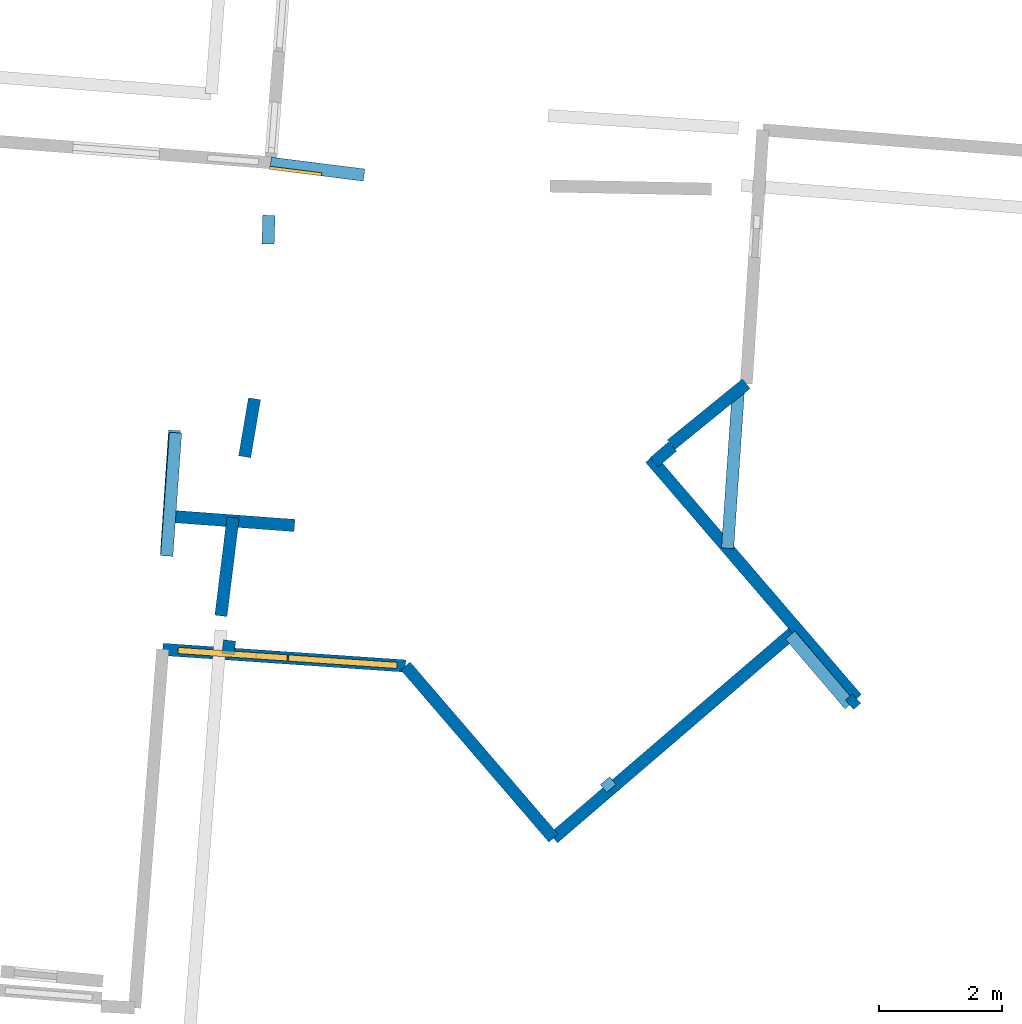
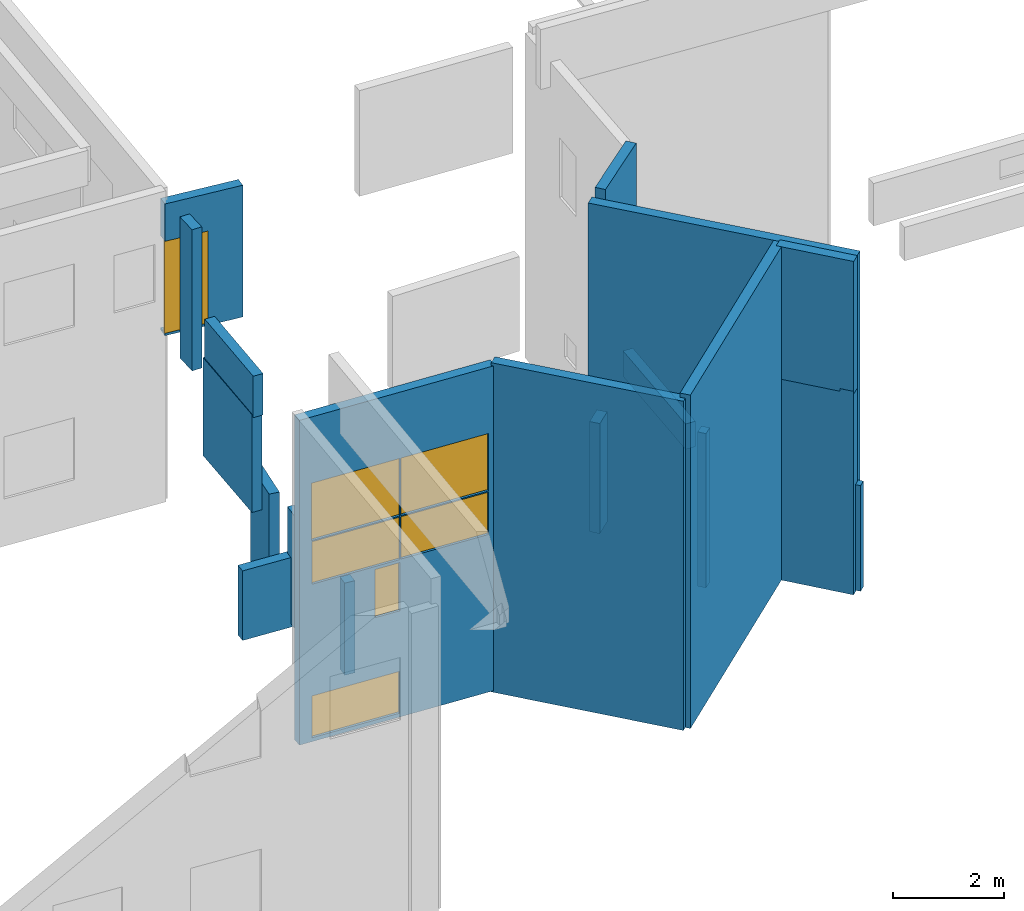
# One storey, part 20 of 27: 19 walls, 6 windows, 1 door, 7 openings.
"""IFC2X3 building model written with IfcOpenShell, lengths in metres."""

from ifc_helpers import new_model, entity, si_unit, converted_unit, derived_unit, direction, frame, frame_2d, origin, origin_2d_with_axis, place, context, subcontext, project, spatial, polyline, rectangle, outline, extrude, source, transform, mapped, material, layer, layer_set, layer_usage, type_object, type_shapes, element, fill, save


model = new_model("IFC2X3")

# Units and contexts
model_context = context("Model", 3, precision=1e-05, world=origin(), true_north=direction((0.0, 1.0)))
body_context = subcontext(model_context, "Body", "Model", "MODEL_VIEW")
ifc_project = project(units=[si_unit("LENGTHUNIT", "METRE"), si_unit("AREAUNIT", "SQUARE_METRE"), si_unit("VOLUMEUNIT", "CUBIC_METRE"), converted_unit("PLANEANGLEUNIT", "DEGREE", entity("IfcRatioMeasure", 0.0174532925199433), si_unit("PLANEANGLEUNIT", "RADIAN"), dimensions=[0, 0, 0, 0, 0, 0, 0]), si_unit("MASSUNIT", "GRAM", prefix="KILO"), derived_unit("MASSDENSITYUNIT", [(si_unit("MASSUNIT", "GRAM", prefix="KILO"), 1), (si_unit("LENGTHUNIT", "METRE"), -3)]), derived_unit("MOMENTOFINERTIAUNIT", [(si_unit("LENGTHUNIT", "METRE"), 4)]), si_unit("TIMEUNIT", "SECOND"), si_unit("FREQUENCYUNIT", "HERTZ"), si_unit("THERMODYNAMICTEMPERATUREUNIT", "DEGREE_CELSIUS"), derived_unit("THERMALTRANSMITTANCEUNIT", [(si_unit("MASSUNIT", "GRAM", prefix="KILO"), 1), (si_unit("THERMODYNAMICTEMPERATUREUNIT", "KELVIN"), -1), (si_unit("TIMEUNIT", "SECOND"), -3)]), derived_unit("VOLUMETRICFLOWRATEUNIT", [(si_unit("LENGTHUNIT", "METRE"), 3), (si_unit("TIMEUNIT", "SECOND"), -1)]), si_unit("ELECTRICCURRENTUNIT", "AMPERE"), si_unit("ELECTRICVOLTAGEUNIT", "VOLT"), si_unit("POWERUNIT", "WATT"), si_unit("FORCEUNIT", "NEWTON", prefix="KILO"), si_unit("ILLUMINANCEUNIT", "LUX"), si_unit("LUMINOUSFLUXUNIT", "LUMEN"), si_unit("LUMINOUSINTENSITYUNIT", "CANDELA"), derived_unit("USERDEFINED", [(si_unit("MASSUNIT", "GRAM", prefix="KILO"), -1), (si_unit("LENGTHUNIT", "METRE"), -2), (si_unit("TIMEUNIT", "SECOND"), 3), (si_unit("LUMINOUSFLUXUNIT", "LUMEN"), 1)]), derived_unit("LINEARVELOCITYUNIT", [(si_unit("LENGTHUNIT", "METRE"), 1), (si_unit("TIMEUNIT", "SECOND"), -1)]), si_unit("PRESSUREUNIT", "PASCAL"), derived_unit("USERDEFINED", [(si_unit("LENGTHUNIT", "METRE"), -2), (si_unit("MASSUNIT", "GRAM", prefix="KILO"), 1), (si_unit("TIMEUNIT", "SECOND"), -2)]), derived_unit("LINEARFORCEUNIT", [(si_unit("MASSUNIT", "GRAM", prefix="KILO"), 1), (si_unit("LENGTHUNIT", "METRE"), 1), (si_unit("TIMEUNIT", "SECOND"), -2), (si_unit("LENGTHUNIT", "METRE"), -1)]), derived_unit("PLANARFORCEUNIT", [(si_unit("MASSUNIT", "GRAM", prefix="KILO"), 1), (si_unit("LENGTHUNIT", "METRE"), 1), (si_unit("TIMEUNIT", "SECOND"), -2), (si_unit("LENGTHUNIT", "METRE"), -2)])], contexts=[model_context])

# Site, building, storey
placement_1 = place(None, origin())
site = spatial("IfcSite", under=ifc_project, at=placement_1, CompositionType="ELEMENT")
building = spatial("IfcBuilding", under=site, at=placement_1, CompositionType="ELEMENT")
storey_placement = place(placement_1, frame((0.0, 0.0, -61.043098449707)))
storey = spatial("IfcBuildingStorey", under=building, at=storey_placement, Name="level_-61.043098", CompositionType="ELEMENT", Elevation=-61.043098449707)

# Walls
ifc_material_1 = material(Name="Default wall")
ifc_layer = layer(ifc_material_1, 0.2)
ifc_layer_set = layer_set([ifc_layer], Name="wall_thickness_0.2000")
ifc_layer_usage = layer_usage(ifc_layer_set, "AXIS2", "POSITIVE", -0.1)
wall_type = type_object("IfcWallType", Name="wall_thickness_0.2000", PredefinedType="STANDARD", material=ifc_layer_set)
placement_2 = place(placement_1, frame((0.0, 0.0, -59.9867630004883)))
wall_1_placement = place(placement_2, frame((3.72674454788199, -11.2180792939364, 0.0), z_axis=(0.0, 0.0, 1.0), x_axis=(-0.122635622552164, -0.992451764108082, 0.0)))
element("IfcWallStandardCase", 1, at=wall_1_placement, inside=storey, type_object=wall_type, material=ifc_layer_usage, Name="Wall:43", ObjectType="Wall", context=body_context, shape_type="SweptSolid", body=[
    extrude(outline(polyline([(1.6065191620896, -0.1), (1.6065191620896, 0.1), (0.0, 0.1), (0.0, -0.1), (1.6065191620896, -0.1)])), origin(), (0.0, 0.0, 1.0), 2.48210144042969),
])
placement_3 = place(placement_1, frame((0.0, 0.0, -56.6423950195312)))
wall_2_placement = place(placement_3, frame((13.7307276761627, -14.256990154621, 0.0), z_axis=(0.0, 0.0, 1.0), x_axis=(-0.648596376151792, 0.761132538289333, 0.0)))
element("IfcWallStandardCase", 2, at=wall_2_placement, inside=storey, type_object=wall_type, material=ifc_layer_usage, Name="Wall:146", ObjectType="Wall", context=body_context, shape_type="SweptSolid", body=[
    extrude(outline(polyline([(1.48869451366512, -0.1), (1.48869451366512, 0.1), (0.0, 0.1), (0.0, -0.1), (1.48869451366512, -0.1)])), origin(), (0.0, 0.0, 1.0), 2.9259033203125),
])

# Wall, opening, door
placement_4 = place(placement_1, frame((0.0, 0.0, -57.3973922729492)))
wall_3_placement = place(placement_4, frame((5.85279650664153, -5.66056494307114, 0.0), z_axis=(0.0, 0.0, 1.0), x_axis=(-0.992131659614174, 0.125198921685551, 0.0)))
wall_3 = element("IfcWallStandardCase", 3, at=wall_3_placement, inside=storey, type_object=wall_type, material=ifc_layer_usage, Name="Wall:167", ObjectType="Wall", context=body_context, shape_type="SweptSolid", body=[
    extrude(outline(polyline([(1.52899989557727, -0.1), (1.52899989557727, 0.1), (0.0, 0.1), (0.0, -0.1), (1.52899989557727, -0.1)])), origin(), (0.0, 0.0, 1.0), 2.90872955322266),
])
opening_1_placement = place(wall_3_placement, frame((0.685000048983913, -0.1, 0.0537300109863281)))
opening_1 = element("IfcOpeningElement", 4, at=opening_1_placement, cuts=wall_3, Name="Opening : 850 x 2030 : 11", ObjectType="Opening", context=body_context, shape_type="SweptSolid", body=[
    extrude(rectangle(XDim=0.85, YDim=2.03, at=frame_2d((1.015, 0.425), x_axis=(0.0, 1.0))), frame((0.0, 0.0, 0.0), z_axis=(0.0, 1.0, 0.0), x_axis=(0.0, 0.0, 1.0)), (0.0, 0.0, 1.0), 0.2),
])
ifc_material_2 = material(Name="Door Panel")
door_style = type_object("IfcDoorStyle", Name="Door : 850 x 2030mm", ConstructionType="NOTDEFINED", OperationType="SINGLE_SWING_RIGHT", ParameterTakesPrecedence=False, Sizeable=False, material=ifc_material_2)
shared_shape_1 = source(origin(), body_context, "Body", "SweptSolid", [
    extrude(rectangle(XDim=0.05, YDim=0.85, at=origin_2d_with_axis()), frame((0.425, 0.175, 0.0), z_axis=(0.0, 0.0, 1.0), x_axis=(0.0, 1.0, 0.0)), (0.0, 0.0, 1.0), 2.03),
])
type_shapes(door_style, [shared_shape_1])
door_placement = place(opening_1_placement, origin())
door = element("IfcDoor", 5, at=door_placement, inside=storey, type_object=door_style, Name="Door : 850 x 2030mm : 1", ObjectType="Door : 850 x 2030mm", OverallHeight=2.03, OverallWidth=0.85, context=body_context, shape_type="MappedRepresentation", body=[
    mapped(shared_shape_1, transform((0.0, 0.0, 0.0), scale=1.0)),
])
fill(opening_1, door)

# Walls
wall_4_placement = place(storey_placement, frame((13.8453943914208, -14.1546270377382, 0.0), z_axis=(0.0, 0.0, 1.0), x_axis=(-0.754916049005397, -0.655821438315401, 0.0)))
element("IfcWallStandardCase", 6, at=wall_4_placement, inside=storey, type_object=wall_type, material=ifc_layer_usage, Name="Wall:279", ObjectType="Wall", context=body_context, shape_type="SweptSolid", body=[
    extrude(outline(polyline([(0.154540212290248, -0.1), (0.154540212290248, 0.1), (0.0, 0.1), (0.0, -0.1), (0.154540212290248, -0.1)])), origin(), (0.0, 0.0, 1.0), 2.33486175537109),
])
placement_5 = place(placement_1, frame((0.0, 0.0, -58.7488288879395)))
wall_5_placement = place(placement_5, frame((9.86514925137134, -15.6132291871711, 0.0), z_axis=(0.0, 0.0, 1.0), x_axis=(-0.63309080364225, 0.774077537681859, 0.0)))
element("IfcWallStandardCase", 7, at=wall_5_placement, inside=storey, type_object=wall_type, material=ifc_layer_usage, Name="Wall:407", ObjectType="Wall", context=body_context, shape_type="SweptSolid", body=[
    extrude(outline(polyline([(0.165718194954943, -0.1), (0.165718194954943, 0.1), (0.0, 0.1), (0.0, -0.1), (0.165718194954943, -0.1)])), origin(), (0.0, 0.0, 1.0), 3.40629577636719),
])
placement_6 = place(placement_1, frame((0.0, 0.0, -58.7488288879395)))
wall_6_placement = place(placement_6, frame((11.7499348355875, -11.7163176477874, 0.0), z_axis=(0.0, 0.0, 1.0), x_axis=(0.0680780800533135, 0.997679996299542, 0.0)))
element("IfcWallStandardCase", 8, at=wall_6_placement, inside=storey, type_object=wall_type, material=ifc_layer_usage, Name="Wall:459", ObjectType="Wall", context=body_context, shape_type="SweptSolid", body=[
    extrude(outline(polyline([(2.57255578706574, -0.1), (2.57255578706574, 0.1), (0.0, 0.1), (0.0, -0.1), (2.57255578706574, -0.1)])), origin(), (0.0, 0.0, 1.0), 0.561229705810547),
])
placement_7 = place(placement_1, frame((0.0, 0.0, -61.0783157348633)))
wall_7_placement = place(placement_7, frame((13.7287289435935, -14.2559767905874, 0.0), z_axis=(0.0, 0.0, 1.0), x_axis=(-0.646113240710319, 0.76324156083039, 0.0)))
element("IfcWallStandardCase", 9, at=wall_7_placement, inside=storey, type_object=wall_type, material=ifc_layer_usage, Name="Wall:535", ObjectType="Wall", context=body_context, shape_type="SweptSolid", body=[
    extrude(outline(polyline([(1.48664756935953, -0.1), (1.48664756935953, 0.1), (0.0, 0.1), (0.0, -0.1), (1.48664756935953, -0.1)])), origin(), (0.0, 0.0, 1.0), 4.49478912353516),
])
placement_8 = place(placement_1, frame((0.0, 0.0, -54.7861137390137)))
wall_8_placement = place(placement_8, frame((2.79352791295688, -9.8407572805784, 0.0), z_axis=(0.0, 0.0, 1.0), x_axis=(-0.0711735971793763, -0.997463943741601, 0.0)))
element("IfcWallStandardCase", 10, at=wall_8_placement, inside=storey, type_object=wall_type, material=ifc_layer_usage, Name="Wall:643", ObjectType="Wall", context=body_context, shape_type="SweptSolid", body=[
    extrude(outline(polyline([(2.00499991556981, -0.1), (2.00499991556981, 0.1), (0.0, 0.1), (0.0, -0.1), (2.00499991556981, -0.1)])), origin(), (0.0, 0.0, 1.0), 0.914207458496094),
])
placement_9 = place(placement_1, frame((0.0, 0.0, -61.0783157348633)))
wall_9_placement = place(placement_9, frame((12.877055778141, -13.0278539800355, 0.0), z_axis=(0.0, 0.0, 1.0), x_axis=(-0.758790844108223, -0.651334364898345, 0.0)))
element("IfcWallStandardCase", 11, at=wall_9_placement, inside=storey, type_object=wall_type, material=ifc_layer_usage, Name="Wall:735", ObjectType="Wall", context=body_context, shape_type="SweptSolid", body=[
    extrude(outline(polyline([(5.2068631766687, -0.1), (5.2068631766687, 0.1), (0.0, 0.1), (0.0, -0.1), (5.2068631766687, -0.1)])), origin(), (0.0, 0.0, 1.0), 7.36182403564453),
])
placement_10 = place(placement_1, frame((0.0, 0.0, -61.0783157348633)))
wall_10_placement = place(placement_10, frame((6.52413124766699, -13.6259891294934, 0.0), z_axis=(0.0, 0.0, 1.0), x_axis=(0.65200642014833, -0.758213444938402, 0.0)))
element("IfcWallStandardCase", 12, at=wall_10_placement, inside=storey, type_object=wall_type, material=ifc_layer_usage, Name="Wall:832", ObjectType="Wall", context=body_context, shape_type="SweptSolid", body=[
    extrude(outline(polyline([(3.68401930980512, -0.1), (3.68401930980512, 0.1), (0.0, 0.1), (0.0, -0.1), (3.68401930980512, -0.1)])), origin(), (0.0, 0.0, 1.0), 7.26918411254883),
])
placement_11 = place(placement_1, frame((0.0, 0.0, -56.9013023376465)))
wall_11_placement = place(placement_11, frame((2.77837817486095, -9.80326750753088, 0.0), z_axis=(0.0, 0.0, 1.0), x_axis=(-0.0665947930889778, -0.997780102794918, 0.0)))
element("IfcWallStandardCase", 13, at=wall_11_placement, inside=storey, type_object=wall_type, material=ifc_layer_usage, Name="Wall:977", ObjectType="Wall", context=body_context, shape_type="SweptSolid", body=[
    extrude(outline(polyline([(2.00499925497424, -0.1), (2.00499925497424, 0.1), (0.0, 0.1), (0.0, -0.1), (2.00499925497424, -0.1)])), origin(), (0.0, 0.0, 1.0), 2.16252899169922),
])
placement_12 = place(placement_1, frame((0.0, 0.0, -60.0665283203125)))
wall_12_placement = place(placement_12, frame((3.91493213467944, -10.2315343285394, 0.0), z_axis=(0.0, 0.0, 1.0), x_axis=(0.167306336880324, 0.985904959739876, 0.0)))
element("IfcWallStandardCase", 14, at=wall_12_placement, inside=storey, type_object=wall_type, material=ifc_layer_usage, Name="Wall:1047", ObjectType="Wall", context=body_context, shape_type="SweptSolid", body=[
    extrude(outline(polyline([(0.955000535399188, -0.1), (0.955000535399188, 0.1), (0.0, 0.1), (0.0, -0.1), (0.955000535399188, -0.1)])), origin(), (0.0, 0.0, 1.0), 2.16623687744141),
])
wall_13_placement = place(storey_placement, frame((10.8581595336881, -10.0632953327282, 0.0), z_axis=(0.0, 0.0, 1.0), x_axis=(-0.759124153920514, -0.650945864826303, 0.0)))
element("IfcWallStandardCase", 15, at=wall_13_placement, inside=storey, type_object=wall_type, material=ifc_layer_usage, Name="Wall:1208", ObjectType="Wall", context=body_context, shape_type="SweptSolid", body=[
    extrude(outline(polyline([(0.40106438837095, -0.1), (0.40106438837095, 0.1), (0.0, 0.1), (0.0, -0.1), (0.40106438837095, -0.1)])), origin(), (0.0, 0.0, 1.0), 2.43098831176758),
])

# Wall, openings, windows
wall_14_placement = place(storey_placement, frame((6.52413051795277, -13.6259896343343, 0.0), z_axis=(0.0, 0.0, 1.0), x_axis=(-0.997670095106908, 0.0682230263867892, 0.0)))
wall_14 = element("IfcWallStandardCase", 16, at=wall_14_placement, inside=storey, type_object=wall_type, material=ifc_layer_usage, Name="Wall:1341", ObjectType="Wall", context=body_context, shape_type="SweptSolid", body=[
    extrude(outline(polyline([(3.94824900385597, -0.1), (3.94824900385597, 0.1), (0.0, 0.1), (0.0, -0.1), (3.94824900385597, -0.1)])), origin(), (0.0, 0.0, 1.0), 7.17119216918945),
])
opening_2_placement = place(wall_14_placement, frame((0.139769048185019, -0.1, 4.43975067138672)))
opening_2 = element("IfcOpeningElement", 17, at=opening_2_placement, cuts=wall_14, Name="Opening : 1765 x 1270 : 209", ObjectType="Opening", context=body_context, shape_type="SweptSolid", body=[
    extrude(rectangle(XDim=1.765, YDim=1.27, at=frame_2d((0.635, 0.8825), x_axis=(0.0, 1.0))), frame((0.0, 0.0, 0.0), z_axis=(0.0, 1.0, 0.0), x_axis=(0.0, 0.0, 1.0)), (0.0, 0.0, 1.0), 0.2),
])
opening_3_placement = place(wall_14_placement, frame((1.91976896516112, -0.1, 4.43975067138672)))
opening_3 = element("IfcOpeningElement", 18, at=opening_3_placement, cuts=wall_14, Name="Opening : 1780 x 1270 : 210", ObjectType="Opening", context=body_context, shape_type="SweptSolid", body=[
    extrude(rectangle(XDim=1.78, YDim=1.27, at=frame_2d((0.635, 0.89), x_axis=(0.0, 1.0))), frame((0.0, 0.0, 0.0), z_axis=(0.0, 1.0, 0.0), x_axis=(0.0, 0.0, 1.0)), (0.0, 0.0, 1.0), 0.2),
])
opening_4_placement = place(wall_14_placement, frame((0.139769048185019, -0.1, 3.4797477722168)))
opening_4 = element("IfcOpeningElement", 19, at=opening_4_placement, cuts=wall_14, Name="Opening : 1760 x 935 : 211", ObjectType="Opening", context=body_context, shape_type="SweptSolid", body=[
    extrude(rectangle(XDim=1.76, YDim=0.935, at=frame_2d((0.4675, 0.88), x_axis=(0.0, 1.0))), frame((0.0, 0.0, 0.0), z_axis=(0.0, 1.0, 0.0), x_axis=(0.0, 0.0, 1.0)), (0.0, 0.0, 1.0), 0.2),
])
opening_5_placement = place(wall_14_placement, frame((1.91976896516112, -0.1, 3.47474670410156)))
opening_5 = element("IfcOpeningElement", 20, at=opening_5_placement, cuts=wall_14, Name="Opening : 1775 x 940 : 212", ObjectType="Opening", context=body_context, shape_type="SweptSolid", body=[
    extrude(rectangle(XDim=1.775, YDim=0.94, at=frame_2d((0.47, 0.8875), x_axis=(0.0, 1.0))), frame((0.0, 0.0, 0.0), z_axis=(0.0, 1.0, 0.0), x_axis=(0.0, 0.0, 1.0)), (0.0, 0.0, 1.0), 0.2),
])
opening_6_placement = place(wall_14_placement, frame((1.92476876398627, -0.1, 2.34474945068359)))
opening_6 = element("IfcOpeningElement", 21, at=opening_6_placement, cuts=wall_14, Name="Opening : 505 x 1065 : 213", ObjectType="Opening", context=body_context, shape_type="SweptSolid", body=[
    extrude(rectangle(XDim=0.505, YDim=1.065, at=frame_2d((0.5325, 0.2525), x_axis=(0.0, 1.0))), frame((0.0, 0.0, 0.0), z_axis=(0.0, 1.0, 0.0), x_axis=(0.0, 0.0, 1.0)), (0.0, 0.0, 1.0), 0.2),
])
opening_7_placement = place(wall_14_placement, frame((1.92976910360013, -0.1, 0.084747314453125)))
opening_7 = element("IfcOpeningElement", 22, at=opening_7_placement, cuts=wall_14, Name="Opening : 1765 x 925 : 214", ObjectType="Opening", context=body_context, shape_type="SweptSolid", body=[
    extrude(rectangle(XDim=1.765, YDim=0.925, at=frame_2d((0.4625, 0.8825), x_axis=(0.0, 1.0))), frame((0.0, 0.0, 0.0), z_axis=(0.0, 1.0, 0.0), x_axis=(0.0, 0.0, 1.0)), (0.0, 0.0, 1.0), 0.2),
])
ifc_material_3 = material(Name="Window Default")
window_style_1 = type_object("IfcWindowStyle", Name="Window : 1765 x 1270mm", ConstructionType="NOTDEFINED", OperationType="NOTDEFINED", ParameterTakesPrecedence=False, Sizeable=False, material=ifc_material_3)
shared_shape_2 = source(origin(), body_context, "Body", "SweptSolid", [
    extrude(rectangle(XDim=0.1, YDim=1.765, at=origin_2d_with_axis()), frame((0.8825, 0.1, 0.0), z_axis=(0.0, 0.0, 1.0), x_axis=(0.0, 1.0, 0.0)), (0.0, 0.0, 1.0), 1.27),
])
type_shapes(window_style_1, [shared_shape_2])
window_1_placement = place(opening_2_placement, origin())
window_1 = element("IfcWindow", 23, at=window_1_placement, inside=storey, type_object=window_style_1, Name="Window : 1765 x 1270mm : 192", ObjectType="Window : 1765 x 1270mm", OverallHeight=1.27, OverallWidth=1.765, context=body_context, shape_type="MappedRepresentation", body=[
    mapped(shared_shape_2, transform((0.0, 0.0, 0.0), scale=1.0)),
])
fill(opening_2, window_1)
window_style_2 = type_object("IfcWindowStyle", Name="Window : 1780 x 1270mm", ConstructionType="NOTDEFINED", OperationType="NOTDEFINED", ParameterTakesPrecedence=False, Sizeable=False, material=ifc_material_3)
shared_shape_3 = source(origin(), body_context, "Body", "SweptSolid", [
    extrude(rectangle(XDim=0.1, YDim=1.78, at=origin_2d_with_axis()), frame((0.89, 0.1, 0.0), z_axis=(0.0, 0.0, 1.0), x_axis=(0.0, 1.0, 0.0)), (0.0, 0.0, 1.0), 1.27),
])
type_shapes(window_style_2, [shared_shape_3])
window_2_placement = place(opening_3_placement, origin())
window_2 = element("IfcWindow", 24, at=window_2_placement, inside=storey, type_object=window_style_2, Name="Window : 1780 x 1270mm : 193", ObjectType="Window : 1780 x 1270mm", OverallHeight=1.27, OverallWidth=1.78, context=body_context, shape_type="MappedRepresentation", body=[
    mapped(shared_shape_3, transform((0.0, 0.0, 0.0), scale=1.0)),
])
fill(opening_3, window_2)
window_style_3 = type_object("IfcWindowStyle", Name="Window : 1760 x 935mm", ConstructionType="NOTDEFINED", OperationType="NOTDEFINED", ParameterTakesPrecedence=False, Sizeable=False, material=ifc_material_3)
shared_shape_4 = source(origin(), body_context, "Body", "SweptSolid", [
    extrude(rectangle(XDim=0.1, YDim=1.76, at=origin_2d_with_axis()), frame((0.88, 0.1, 0.0), z_axis=(0.0, 0.0, 1.0), x_axis=(0.0, 1.0, 0.0)), (0.0, 0.0, 1.0), 0.935),
])
type_shapes(window_style_3, [shared_shape_4])
window_3_placement = place(opening_4_placement, origin())
window_3 = element("IfcWindow", 25, at=window_3_placement, inside=storey, type_object=window_style_3, Name="Window : 1760 x 935mm : 194", ObjectType="Window : 1760 x 935mm", OverallHeight=0.935, OverallWidth=1.76, context=body_context, shape_type="MappedRepresentation", body=[
    mapped(shared_shape_4, transform((0.0, 0.0, 0.0), scale=1.0)),
])
fill(opening_4, window_3)
window_style_4 = type_object("IfcWindowStyle", Name="Window : 1775 x 940mm", ConstructionType="NOTDEFINED", OperationType="NOTDEFINED", ParameterTakesPrecedence=False, Sizeable=False, material=ifc_material_3)
shared_shape_5 = source(origin(), body_context, "Body", "SweptSolid", [
    extrude(rectangle(XDim=0.1, YDim=1.775, at=origin_2d_with_axis()), frame((0.8875, 0.1, 0.0), z_axis=(0.0, 0.0, 1.0), x_axis=(0.0, 1.0, 0.0)), (0.0, 0.0, 1.0), 0.94),
])
type_shapes(window_style_4, [shared_shape_5])
window_4_placement = place(opening_5_placement, origin())
window_4 = element("IfcWindow", 26, at=window_4_placement, inside=storey, type_object=window_style_4, Name="Window : 1775 x 940mm : 195", ObjectType="Window : 1775 x 940mm", OverallHeight=0.94, OverallWidth=1.775, context=body_context, shape_type="MappedRepresentation", body=[
    mapped(shared_shape_5, transform((0.0, 0.0, 0.0), scale=1.0)),
])
fill(opening_5, window_4)
window_style_5 = type_object("IfcWindowStyle", Name="Window : 505 x 1065mm", ConstructionType="NOTDEFINED", OperationType="NOTDEFINED", ParameterTakesPrecedence=False, Sizeable=False, material=ifc_material_3)
shared_shape_6 = source(origin(), body_context, "Body", "SweptSolid", [
    extrude(rectangle(XDim=0.1, YDim=0.505, at=origin_2d_with_axis()), frame((0.2525, 0.1, 0.0), z_axis=(0.0, 0.0, 1.0), x_axis=(0.0, 1.0, 0.0)), (0.0, 0.0, 1.0), 1.065),
])
type_shapes(window_style_5, [shared_shape_6])
window_5_placement = place(opening_6_placement, origin())
window_5 = element("IfcWindow", 27, at=window_5_placement, inside=storey, type_object=window_style_5, Name="Window : 505 x 1065mm : 196", ObjectType="Window : 505 x 1065mm", OverallHeight=1.065, OverallWidth=0.505, context=body_context, shape_type="MappedRepresentation", body=[
    mapped(shared_shape_6, transform((0.0, 0.0, 0.0), scale=1.0)),
])
fill(opening_6, window_5)
window_style_6 = type_object("IfcWindowStyle", Name="Window : 1765 x 925mm", ConstructionType="NOTDEFINED", OperationType="NOTDEFINED", ParameterTakesPrecedence=False, Sizeable=False, material=ifc_material_3)
shared_shape_7 = source(origin(), body_context, "Body", "SweptSolid", [
    extrude(rectangle(XDim=0.1, YDim=1.765, at=origin_2d_with_axis()), frame((0.8825, 0.1, 0.0), z_axis=(0.0, 0.0, 1.0), x_axis=(0.0, 1.0, 0.0)), (0.0, 0.0, 1.0), 0.925),
])
type_shapes(window_style_6, [shared_shape_7])
window_6_placement = place(opening_7_placement, origin())
window_6 = element("IfcWindow", 28, at=window_6_placement, inside=storey, type_object=window_style_6, Name="Window : 1765 x 925mm : 197", ObjectType="Window : 1765 x 925mm", OverallHeight=0.925, OverallWidth=1.765, context=body_context, shape_type="MappedRepresentation", body=[
    mapped(shared_shape_7, transform((0.0, 0.0, 0.0), scale=1.0)),
])
fill(opening_7, window_6)

# Walls
placement_13 = place(placement_1, frame((0.0, 0.0, -61.0783157348633)))
wall_15_placement = place(placement_13, frame((10.4955345351946, -10.2566838009441, 0.0), z_axis=(0.0, 0.0, 1.0), x_axis=(0.651774292789162, -0.75841299518085, 0.0)))
element("IfcWallStandardCase", 29, at=wall_15_placement, inside=storey, type_object=wall_type, material=ifc_layer_usage, Name="Wall:1347", ObjectType="Wall", context=body_context, shape_type="SweptSolid", body=[
    extrude(outline(polyline([(5.13960158970068, -0.1), (5.13960158970068, 0.1), (0.0, 0.1), (0.0, -0.1), (5.13960158970068, -0.1)])), origin(), (0.0, 0.0, 1.0), 7.36182403564453),
])
placement_14 = place(placement_1, frame((0.0, 0.0, -57.3973922729492)))
wall_16_placement = place(placement_14, frame((4.30892272376845, -6.31387478665128, 0.0), z_axis=(0.0, 0.0, 1.0), x_axis=(-0.0318342777668962, -0.999493160936612, 0.0)))
element("IfcWallStandardCase", 30, at=wall_16_placement, inside=storey, type_object=wall_type, material=ifc_layer_usage, Name="Wall:1573", ObjectType="Wall", context=body_context, shape_type="SweptSolid", body=[
    extrude(outline(polyline([(0.464999798256804, -0.1), (0.464999798256804, 0.1), (0.0, 0.1), (0.0, -0.1), (0.464999798256804, -0.1)])), origin(), (0.0, 0.0, 1.0), 3.11648559570312),
])
placement_15 = place(placement_1, frame((0.0, 0.0, -59.860912322998)))
wall_17_placement = place(placement_15, frame((3.67136850890458, -13.2107685520527, 0.0), z_axis=(0.0, 0.0, 1.0), x_axis=(-0.113799880920999, -0.993503692545914, 0.0)))
element("IfcWallStandardCase", 31, at=wall_17_placement, inside=storey, type_object=wall_type, material=ifc_layer_usage, Name="Wall:1580", ObjectType="Wall", context=body_context, shape_type="SweptSolid", body=[
    extrude(outline(polyline([(0.219860709216782, -0.1), (0.219860709216782, 0.1), (0.0, 0.1), (0.0, -0.1), (0.219860709216782, -0.1)])), origin(), (0.0, 0.0, 1.0), 2.03238677978516),
])
wall_18_placement = place(storey_placement, frame((12.0529314350347, -9.04579860109617, 0.0), z_axis=(0.0, 0.0, 1.0), x_axis=(-0.775982890146004, -0.630753956944113, 0.0)))
element("IfcWallStandardCase", 32, at=wall_18_placement, inside=storey, type_object=wall_type, material=ifc_layer_usage, Name="Wall:1722", ObjectType="Wall", context=body_context, shape_type="SweptSolid", body=[
    extrude(outline(polyline([(1.56722746878582, -0.1), (1.56722746878582, 0.1), (0.0, 0.1), (0.0, -0.1), (1.56722746878582, -0.1)])), origin(), (0.0, 0.0, 1.0), 7.32660675048828),
])
placement_16 = place(placement_1, frame((0.0, 0.0, -60.0665283203125)))
wall_19_placement = place(placement_16, frame((2.64973203804175, -11.1923654721061, 0.0), z_axis=(0.0, 0.0, 1.0), x_axis=(0.997278081105178, -0.0737321432427865, 0.0)))
element("IfcWallStandardCase", 33, at=wall_19_placement, inside=storey, type_object=wall_type, material=ifc_layer_usage, Name="Wall:1821", ObjectType="Wall", context=body_context, shape_type="SweptSolid", body=[
    extrude(outline(polyline([(2.08014729419552, -0.1), (2.08014729419552, 0.1), (0.0, 0.1), (0.0, -0.1), (2.08014729419552, -0.1)])), origin(), (0.0, 0.0, 1.0), 1.536865234375),
])

save(model, "model.ifc")
